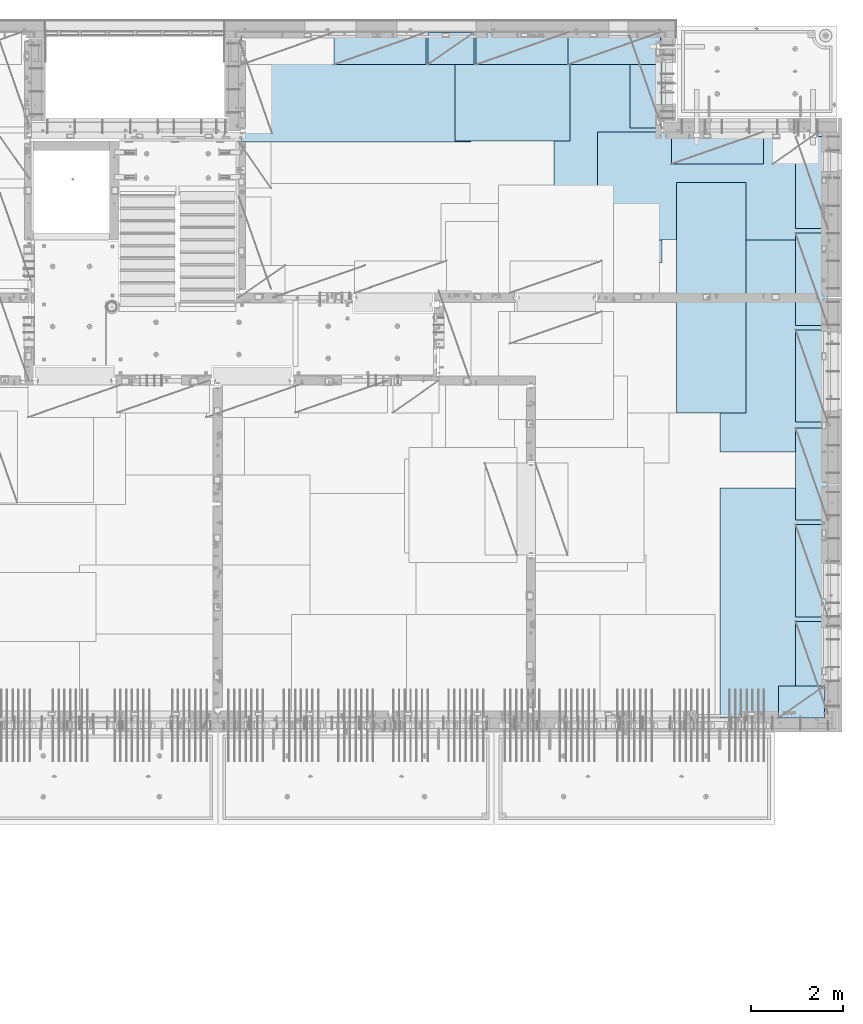
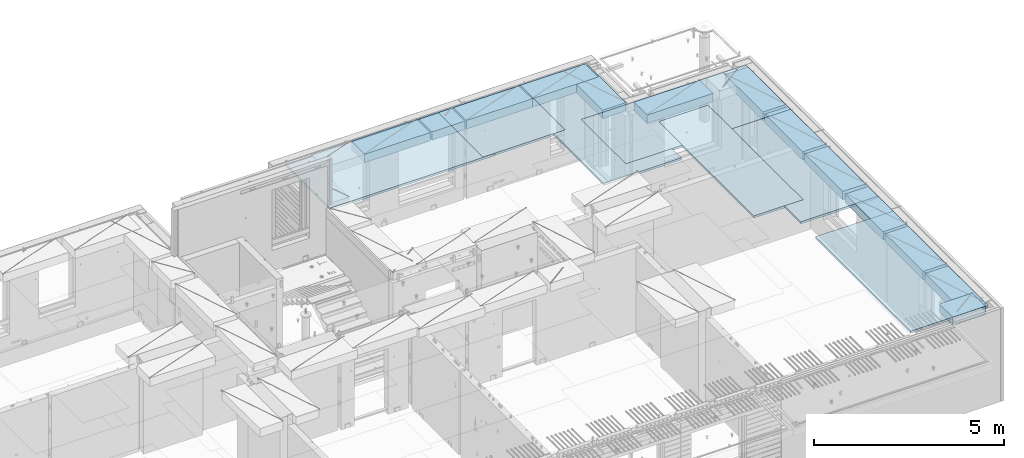
# One storey, part 211 of 350: 20 plates, 20 elements without a shape of their own.
"""IFC2X3 building model written with IfcOpenShell, lengths in millimetres."""

from ifc_helpers import new_model, si_unit, frame, origin_with_axes, place, context, subcontext, project, spatial, faceted_brep, material, type_object, element, aggregate, save


model = new_model("IFC2X3")

# Units and contexts
model_context = context("Model", 3, precision=1e-05, world=origin_with_axes())
body_context = subcontext(model_context, "Body", "Model", "MODEL_VIEW")
ifc_project = project(units=[si_unit("LENGTHUNIT", "METRE", prefix="MILLI"), si_unit("AREAUNIT", "SQUARE_METRE"), si_unit("VOLUMEUNIT", "CUBIC_METRE"), si_unit("MASSUNIT", "GRAM", prefix="KILO"), si_unit("TIMEUNIT", "SECOND"), si_unit("PLANEANGLEUNIT", "RADIAN"), si_unit("SOLIDANGLEUNIT", "STERADIAN"), si_unit("THERMODYNAMICTEMPERATUREUNIT", "DEGREE_CELSIUS"), si_unit("LUMINOUSINTENSITYUNIT", "LUMEN")], contexts=[model_context])

# Site, building, storey
site_placement = place(None, origin_with_axes())
site = spatial("IfcSite", under=ifc_project, at=site_placement, CompositionType="ELEMENT")
building_placement = place(site_placement, origin_with_axes())
building = spatial("IfcBuilding", under=site, at=building_placement, CompositionType="ELEMENT")
storey_placement = place(building_placement, origin_with_axes())
storey = spatial("IfcBuildingStorey", under=building, at=storey_placement, Name="2", CompositionType="ELEMENT", Elevation=0.0)

# Assembly, plate
assembly_1_placement = place(storey_placement, origin_with_axes())
assembly_1 = element("IfcElementAssembly", 1, at=assembly_1_placement, inside=storey, Name="Steel Assembly", AssemblyPlace="NOTDEFINED", PredefinedType="NOTDEFINED")
ifc_material = material()
plate_type_1 = type_object("IfcPlateType", PredefinedType="NOTDEFINED")
plate_1_placement = place(assembly_1_placement, frame((26960.07, 22728.45, 87695.1), z_axis=(1.0, 0.0, 0.0), x_axis=(0.0, -1.0, 0.0)))
plate_1 = element("IfcPlate", 2, at=plate_1_placement, type_object=plate_type_1, material=ifc_material, Name="1/2", context=body_context, shape_type="Brep", body=[
    faceted_brep([(0.0, -35.0, 0.0), (0.0, -35.0, 2500.0), (0.0, 35.0, 2500.0), (0.0, 35.0, 0.0), (2349.99951171875, -35.0, 2500.0), (2349.99951171875, 35.0, 2500.0), (2350.0, -35.0, 0.0), (2350.0, 35.0, 0.0)], [[[0, 1, 2, 3]], [[1, 4, 5, 2]], [[4, 6, 7, 5]], [[6, 0, 3, 7]], [[5, 7, 3, 2]], [[6, 4, 1, 0]]]),
])
aggregate(assembly_1, [plate_1])

assembly_2_placement = place(storey_placement, origin_with_axes())
assembly_2 = element("IfcElementAssembly", 3, at=assembly_2_placement, inside=storey, Name="Steel Assembly", AssemblyPlace="NOTDEFINED", PredefinedType="NOTDEFINED")
plate_2_placement = place(assembly_2_placement, frame((22309.9998779297, 22710.0009765625, 87695.1), z_axis=(1.0, 0.0, 0.0), x_axis=(0.0, -1.0, 0.0)))
plate_2 = element("IfcPlate", 4, at=plate_2_placement, type_object=plate_type_1, material=ifc_material, context=body_context, shape_type="Brep", body=[
    faceted_brep([(0.0, -35.0, 0.0), (0.0, -35.0, 5000.0), (0.0, 35.0, 5000.0), (0.0, 35.0, 0.0), (2349.99951171875, -35.0, 5000.0), (2349.99951171875, 35.0, 5000.0), (2350.0, -35.0, 0.0), (2350.0, 35.0, 0.0)], [[[0, 1, 2, 3]], [[1, 4, 5, 2]], [[4, 6, 7, 5]], [[6, 0, 3, 7]], [[5, 7, 3, 2]], [[6, 4, 1, 0]]]),
])
aggregate(assembly_2, [plate_2])

assembly_3_placement = place(storey_placement, origin_with_axes())
assembly_3 = element("IfcElementAssembly", 5, at=assembly_3_placement, inside=storey, Name="Steel Assembly", AssemblyPlace="NOTDEFINED", PredefinedType="NOTDEFINED")
plate_3_placement = place(assembly_3_placement, frame((31460.0, 22740.0, 87695.1), z_axis=(0.0, -1.0, 0.0), x_axis=(-1.0, 3.00000001838171e-08, 0.0)))
plate_3 = element("IfcPlate", 6, at=plate_3_placement, type_object=plate_type_1, material=ifc_material, context=body_context, shape_type="Brep", body=[
    faceted_brep([(0.0, -35.0, 0.0), (0.0, -35.0, 5000.0), (0.0, 35.0, 5000.0), (0.0, 35.0, 0.0), (2349.99951171875, -35.0, 5000.0), (2349.99951171875, 35.0, 5000.0), (2350.0, -35.0, 0.0), (2350.0, 35.0, 0.0)], [[[0, 1, 2, 3]], [[1, 4, 5, 2]], [[4, 6, 7, 5]], [[6, 0, 3, 7]], [[5, 7, 3, 2]], [[6, 4, 1, 0]]]),
])
aggregate(assembly_3, [plate_3])

assembly_4_placement = place(storey_placement, origin_with_axes())
assembly_4 = element("IfcElementAssembly", 7, at=assembly_4_placement, inside=storey, Name="Steel Assembly", AssemblyPlace="NOTDEFINED", PredefinedType="NOTDEFINED")
plate_4_placement = place(assembly_4_placement, frame((35060.0, 12850.0, 87695.1), z_axis=(0.0, -1.0, 0.0), x_axis=(-1.0, 3.00000001838171e-08, 0.0)))
plate_4 = element("IfcPlate", 8, at=plate_4_placement, type_object=plate_type_1, material=ifc_material, context=body_context, shape_type="Brep", body=[
    faceted_brep([(0.0, -35.0, 0.0), (0.0, -35.0, 5000.0), (0.0, 35.0, 5000.0), (0.0, 35.0, 0.0), (2349.99951171875, -35.0, 5000.0), (2349.99951171875, 35.0, 5000.0), (2350.0, -35.0, 0.0), (2350.0, 35.0, 0.0)], [[[0, 1, 2, 3]], [[1, 4, 5, 2]], [[4, 6, 7, 5]], [[6, 0, 3, 7]], [[5, 7, 3, 2]], [[6, 4, 1, 0]]]),
])
aggregate(assembly_4, [plate_4])

assembly_5_placement = place(storey_placement, origin_with_axes())
assembly_5 = element("IfcElementAssembly", 9, at=assembly_5_placement, inside=storey, Name="Steel Assembly", AssemblyPlace="NOTDEFINED", PredefinedType="NOTDEFINED")
plate_5_placement = place(assembly_5_placement, frame((35060.0, 18630.0, 87695.1), z_axis=(0.0, -1.0, 0.0), x_axis=(-1.0, 3.00000001838171e-08, 0.0)))
plate_5 = element("IfcPlate", 10, at=plate_5_placement, type_object=plate_type_1, material=ifc_material, context=body_context, shape_type="Brep", body=[
    faceted_brep([(0.0, -35.0, 0.0), (0.0, -35.0, 5000.0), (0.0, 35.0, 5000.0), (0.0, 35.0, 0.0), (2349.99951171875, -35.0, 5000.0), (2349.99951171875, 35.0, 5000.0), (2350.0, -35.0, 0.0), (2350.0, 35.0, 0.0)], [[[0, 1, 2, 3]], [[1, 4, 5, 2]], [[4, 6, 7, 5]], [[6, 0, 3, 7]], [[5, 7, 3, 2]], [[6, 4, 1, 0]]]),
])
aggregate(assembly_5, [plate_5])

assembly_6_placement = place(storey_placement, origin_with_axes())
assembly_6 = element("IfcElementAssembly", 11, at=assembly_6_placement, inside=storey, Name="Steel Assembly", AssemblyPlace="NOTDEFINED", PredefinedType="NOTDEFINED")
plate_6_placement = place(assembly_6_placement, frame((30060.0, 20580.0, 87695.1), z_axis=(1.0, 0.0, 0.0), x_axis=(0.0, -1.0, 0.0)))
plate_6 = element("IfcPlate", 12, at=plate_6_placement, type_object=plate_type_1, material=ifc_material, context=body_context, shape_type="Brep", body=[
    faceted_brep([(0.0, -35.0, 0.0), (0.0, -35.0, 5000.0), (0.0, 35.0, 5000.0), (0.0, 35.0, 0.0), (2349.99951171875, -35.0, 5000.0), (2349.99951171875, 35.0, 5000.0), (2350.0, -35.0, 0.0), (2350.0, 35.0, 0.0)], [[[0, 1, 2, 3]], [[1, 4, 5, 2]], [[4, 6, 7, 5]], [[6, 0, 3, 7]], [[5, 7, 3, 2]], [[6, 4, 1, 0]]]),
])
aggregate(assembly_6, [plate_6])

assembly_7_placement = place(storey_placement, origin_with_axes())
assembly_7 = element("IfcElementAssembly", 13, at=assembly_7_placement, inside=storey, Name="Steel Assembly", AssemblyPlace="NOTDEFINED", PredefinedType="NOTDEFINED")
plate_type_2 = type_object("IfcPlateType", PredefinedType="NOTDEFINED")
plate_7_placement = place(assembly_7_placement, frame((33275.0000122641, 19480.0, 87695.1000003815), z_axis=(0.0, -1.0, 0.0), x_axis=(-1.0, 3.00000001838171e-08, 0.0)))
plate_7 = element("IfcPlate", 14, at=plate_7_placement, type_object=plate_type_2, material=ifc_material, context=body_context, shape_type="Brep", body=[
    faceted_brep([(0.0, -35.0, 0.0), (0.0, -35.0, 5000.0), (0.0, 35.0, 5000.0), (0.0, 35.0, 0.0), (1499.99951171875, -35.0, 5000.0), (1499.99951171875, 35.0, 5000.0), (1500.0, -35.0, 0.0), (1500.0, 35.0, 0.0)], [[[0, 1, 2, 3]], [[1, 4, 5, 2]], [[4, 6, 7, 5]], [[6, 0, 3, 7]], [[5, 7, 3, 2]], [[6, 4, 1, 0]]]),
])
aggregate(assembly_7, [plate_7])

assembly_8_placement = place(storey_placement, origin_with_axes())
assembly_8 = element("IfcElementAssembly", 15, at=assembly_8_placement, inside=storey, Name="Steel Assembly", AssemblyPlace="NOTDEFINED", PredefinedType="NOTDEFINED")
plate_type_3 = type_object("IfcPlateType", PredefinedType="NOTDEFINED")
plate_8_placement = place(assembly_8_placement, frame((31420.0, 22740.0001220703, 87595.3), z_axis=(0.0, -1.0, 0.0), x_axis=(-1.0, 3.00000001838171e-08, 0.0)))
plate_8 = element("IfcPlate", 16, at=plate_8_placement, type_object=plate_type_3, material=ifc_material, Name="RE1", context=body_context, shape_type="Brep", body=[
    faceted_brep([(1.81898940354586e-12, -135.0, 1.81898940354586e-12), (0.0, -135.0, 699.999999999996), (0.0, 135.0, 699.999999999996), (1.81898940354586e-12, 135.0, 1.81898940354586e-12), (1999.99951171875, -135.0, 699.999999999993), (1999.99951171875, 135.0, 699.999999999993), (2000.0, -135.0, -3.63797880709171e-12), (2000.0, 135.0, -3.63797880709171e-12)], [[[0, 1, 2, 3]], [[1, 4, 5, 2]], [[4, 6, 7, 5]], [[6, 0, 3, 7]], [[5, 7, 3, 2]], [[6, 4, 1, 0]]]),
])
aggregate(assembly_8, [plate_8])

assembly_9_placement = place(storey_placement, origin_with_axes())
assembly_9 = element("IfcElementAssembly", 17, at=assembly_9_placement, inside=storey, Name="Steel Assembly", AssemblyPlace="NOTDEFINED", PredefinedType="NOTDEFINED")
plate_9_placement = place(assembly_9_placement, frame((33985.0, 7849.99999992931, 87595.3), z_axis=(0.0, 1.0, 0.0), x_axis=(1.0, 0.0, 0.0)))
plate_9 = element("IfcPlate", 18, at=plate_9_placement, type_object=plate_type_3, material=ifc_material, Name="RE1_1/2", context=body_context, shape_type="Brep", body=[
    faceted_brep([(1.81898940354586e-12, -135.0, 1.81898940354586e-12), (0.0, -135.0, 699.999999999996), (0.0, 135.0, 699.999999999996), (1.81898940354586e-12, 135.0, 1.81898940354586e-12), (999.99951171875, -135.0, 700.0), (999.99951171875, 135.0, 700.0), (1000.0, -135.0, 0.0), (1000.0, 135.0, 0.0)], [[[0, 1, 2, 3]], [[1, 4, 5, 2]], [[4, 6, 7, 5]], [[6, 0, 3, 7]], [[5, 7, 3, 2]], [[6, 4, 1, 0]]]),
])
aggregate(assembly_9, [plate_9])

assembly_10_placement = place(storey_placement, origin_with_axes())
assembly_10 = element("IfcElementAssembly", 19, at=assembly_10_placement, inside=storey, Name="Steel Assembly", AssemblyPlace="NOTDEFINED", PredefinedType="NOTDEFINED")
plate_10_placement = place(assembly_10_placement, frame((35060.0001220703, 14280.0, 87595.3), z_axis=(-1.0, 3.00000001838171e-08, 0.0), x_axis=(0.0, 1.0, 0.0)))
plate_10 = element("IfcPlate", 20, at=plate_10_placement, type_object=plate_type_3, material=ifc_material, Name="RE1", context=body_context, shape_type="Brep", body=[
    faceted_brep([(1.81898940354586e-12, -135.0, 1.81898940354586e-12), (0.0, -135.0, 699.999999999996), (0.0, 135.0, 699.999999999996), (1.81898940354586e-12, 135.0, 1.81898940354586e-12), (1999.99951171875, -135.0, 699.999999999993), (1999.99951171875, 135.0, 699.999999999993), (2000.0, -135.0, -3.63797880709171e-12), (2000.0, 135.0, -3.63797880709171e-12)], [[[0, 1, 2, 3]], [[1, 4, 5, 2]], [[4, 6, 7, 5]], [[6, 0, 3, 7]], [[5, 7, 3, 2]], [[6, 4, 1, 0]]]),
])
aggregate(assembly_10, [plate_10])

assembly_11_placement = place(storey_placement, origin_with_axes())
assembly_11 = element("IfcElementAssembly", 21, at=assembly_11_placement, inside=storey, Name="Steel Assembly", AssemblyPlace="NOTDEFINED", PredefinedType="NOTDEFINED")
plate_11_placement = place(assembly_11_placement, frame((35060.0001220703, 16380.0, 87595.3), z_axis=(-1.0, 3.00000001838171e-08, 0.0), x_axis=(0.0, 1.0, 0.0)))
plate_11 = element("IfcPlate", 22, at=plate_11_placement, type_object=plate_type_3, material=ifc_material, Name="RE1", context=body_context, shape_type="Brep", body=[
    faceted_brep([(1.81898940354586e-12, -135.0, 1.81898940354586e-12), (0.0, -135.0, 699.999999999996), (0.0, 135.0, 699.999999999996), (1.81898940354586e-12, 135.0, 1.81898940354586e-12), (1999.99951171875, -135.0, 699.999999999993), (1999.99951171875, 135.0, 699.999999999993), (2000.0, -135.0, -3.63797880709171e-12), (2000.0, 135.0, -3.63797880709171e-12)], [[[0, 1, 2, 3]], [[1, 4, 5, 2]], [[4, 6, 7, 5]], [[6, 0, 3, 7]], [[5, 7, 3, 2]], [[6, 4, 1, 0]]]),
])
aggregate(assembly_11, [plate_11])

assembly_12_placement = place(storey_placement, origin_with_axes())
assembly_12 = element("IfcElementAssembly", 23, at=assembly_12_placement, inside=storey, Name="Steel Assembly", AssemblyPlace="NOTDEFINED", PredefinedType="NOTDEFINED")
plate_12_placement = place(assembly_12_placement, frame((35060.0001220703, 18480.0, 87595.3), z_axis=(-1.0, 3.00000001838171e-08, 0.0), x_axis=(0.0, 1.0, 0.0)))
plate_12 = element("IfcPlate", 24, at=plate_12_placement, type_object=plate_type_3, material=ifc_material, Name="RE1", context=body_context, shape_type="Brep", body=[
    faceted_brep([(1.81898940354586e-12, -135.0, 1.81898940354586e-12), (0.0, -135.0, 699.999999999996), (0.0, 135.0, 699.999999999996), (1.81898940354586e-12, 135.0, 1.81898940354586e-12), (1999.99951171875, -135.0, 699.999999999993), (1999.99951171875, 135.0, 699.999999999993), (2000.0, -135.0, -3.63797880709171e-12), (2000.0, 135.0, -3.63797880709171e-12)], [[[0, 1, 2, 3]], [[1, 4, 5, 2]], [[4, 6, 7, 5]], [[6, 0, 3, 7]], [[5, 7, 3, 2]], [[6, 4, 1, 0]]]),
])
aggregate(assembly_12, [plate_12])

assembly_13_placement = place(storey_placement, origin_with_axes())
assembly_13 = element("IfcElementAssembly", 25, at=assembly_13_placement, inside=storey, Name="Steel Assembly", AssemblyPlace="NOTDEFINED", PredefinedType="NOTDEFINED")
plate_13_placement = place(assembly_13_placement, frame((35060.0001220703, 12150.0, 87595.3), z_axis=(-1.0, 3.00000001838171e-08, 0.0), x_axis=(0.0, 1.0, 0.0)))
plate_13 = element("IfcPlate", 26, at=plate_13_placement, type_object=plate_type_3, material=ifc_material, Name="RE1", context=body_context, shape_type="Brep", body=[
    faceted_brep([(1.81898940354586e-12, -135.0, 1.81898940354586e-12), (0.0, -135.0, 699.999999999996), (0.0, 135.0, 699.999999999996), (1.81898940354586e-12, 135.0, 1.81898940354586e-12), (1999.99951171875, -135.0, 699.999999999993), (1999.99951171875, 135.0, 699.999999999993), (2000.0, -135.0, -3.63797880709171e-12), (2000.0, 135.0, -3.63797880709171e-12)], [[[0, 1, 2, 3]], [[1, 4, 5, 2]], [[4, 6, 7, 5]], [[6, 0, 3, 7]], [[5, 7, 3, 2]], [[6, 4, 1, 0]]]),
])
aggregate(assembly_13, [plate_13])

assembly_14_placement = place(storey_placement, origin_with_axes())
assembly_14 = element("IfcElementAssembly", 27, at=assembly_14_placement, inside=storey, Name="Steel Assembly", AssemblyPlace="NOTDEFINED", PredefinedType="NOTDEFINED")
plate_14_placement = place(assembly_14_placement, frame((35060.0001220703, 10050.0, 87595.3), z_axis=(-1.0, 3.00000001838171e-08, 0.0), x_axis=(0.0, 1.0, 0.0)))
plate_14 = element("IfcPlate", 28, at=plate_14_placement, type_object=plate_type_3, material=ifc_material, Name="RE1", context=body_context, shape_type="Brep", body=[
    faceted_brep([(1.81898940354586e-12, -135.0, 1.81898940354586e-12), (0.0, -135.0, 699.999999999996), (0.0, 135.0, 699.999999999996), (1.81898940354586e-12, 135.0, 1.81898940354586e-12), (1999.99951171875, -135.0, 699.999999999993), (1999.99951171875, 135.0, 699.999999999993), (2000.0, -135.0, -3.63797880709171e-12), (2000.0, 135.0, -3.63797880709171e-12)], [[[0, 1, 2, 3]], [[1, 4, 5, 2]], [[4, 6, 7, 5]], [[6, 0, 3, 7]], [[5, 7, 3, 2]], [[6, 4, 1, 0]]]),
])
aggregate(assembly_14, [plate_14])

assembly_15_placement = place(storey_placement, origin_with_axes())
assembly_15 = element("IfcElementAssembly", 29, at=assembly_15_placement, inside=storey, Name="Steel Assembly", AssemblyPlace="NOTDEFINED", PredefinedType="NOTDEFINED")
plate_15_placement = place(assembly_15_placement, frame((35060.0001220703, 7950.0, 87595.3), z_axis=(-1.0, 3.00000001838171e-08, 0.0), x_axis=(0.0, 1.0, 0.0)))
plate_15 = element("IfcPlate", 30, at=plate_15_placement, type_object=plate_type_3, material=ifc_material, Name="RE1", context=body_context, shape_type="Brep", body=[
    faceted_brep([(1.81898940354586e-12, -135.0, 1.81898940354586e-12), (0.0, -135.0, 699.999999999996), (0.0, 135.0, 699.999999999996), (1.81898940354586e-12, 135.0, 1.81898940354586e-12), (1999.99951171875, -135.0, 699.999999999993), (1999.99951171875, 135.0, 699.999999999993), (2000.0, -135.0, -3.63797880709171e-12), (2000.0, 135.0, -3.63797880709171e-12)], [[[0, 1, 2, 3]], [[1, 4, 5, 2]], [[4, 6, 7, 5]], [[6, 0, 3, 7]], [[5, 7, 3, 2]], [[6, 4, 1, 0]]]),
])
aggregate(assembly_15, [plate_15])

assembly_16_placement = place(storey_placement, origin_with_axes())
assembly_16 = element("IfcElementAssembly", 31, at=assembly_16_placement, inside=storey, Name="Steel Assembly", AssemblyPlace="NOTDEFINED", PredefinedType="NOTDEFINED")
plate_16_placement = place(assembly_16_placement, frame((33660.0, 20580.0001220703, 87595.3), z_axis=(0.0, -1.0, 0.0), x_axis=(-1.0, 3.00000001838171e-08, 0.0)))
plate_16 = element("IfcPlate", 32, at=plate_16_placement, type_object=plate_type_3, material=ifc_material, Name="RE1", context=body_context, shape_type="Brep", body=[
    faceted_brep([(1.81898940354586e-12, -135.0, 1.81898940354586e-12), (0.0, -135.0, 699.999999999996), (0.0, 135.0, 699.999999999996), (1.81898940354586e-12, 135.0, 1.81898940354586e-12), (1999.99951171875, -135.0, 699.999999999993), (1999.99951171875, 135.0, 699.999999999993), (2000.0, -135.0, -3.63797880709171e-12), (2000.0, 135.0, -3.63797880709171e-12)], [[[0, 1, 2, 3]], [[1, 4, 5, 2]], [[4, 6, 7, 5]], [[6, 0, 3, 7]], [[5, 7, 3, 2]], [[6, 4, 1, 0]]]),
])
aggregate(assembly_16, [plate_16])

assembly_17_placement = place(storey_placement, origin_with_axes())
assembly_17 = element("IfcElementAssembly", 33, at=assembly_17_placement, inside=storey, Name="Steel Assembly", AssemblyPlace="NOTDEFINED", PredefinedType="NOTDEFINED")
plate_17_placement = place(assembly_17_placement, frame((31460.0001220703, 20660.0, 87595.3), z_axis=(-1.0, 3.00000001838171e-08, 0.0), x_axis=(0.0, 1.0, 0.0)))
plate_17 = element("IfcPlate", 34, at=plate_17_placement, type_object=plate_type_3, material=ifc_material, Name="RE1", context=body_context, shape_type="Brep", body=[
    faceted_brep([(1.81898940354586e-12, -135.0, 1.81898940354586e-12), (0.0, -135.0, 699.999999999996), (0.0, 135.0, 699.999999999996), (1.81898940354586e-12, 135.0, 1.81898940354586e-12), (1999.99951171875, -135.0, 699.999999999993), (1999.99951171875, 135.0, 699.999999999993), (2000.0, -135.0, -3.63797880709171e-12), (2000.0, 135.0, -3.63797880709171e-12)], [[[0, 1, 2, 3]], [[1, 4, 5, 2]], [[4, 6, 7, 5]], [[6, 0, 3, 7]], [[5, 7, 3, 2]], [[6, 4, 1, 0]]]),
])
aggregate(assembly_17, [plate_17])

assembly_18_placement = place(storey_placement, origin_with_axes())
assembly_18 = element("IfcElementAssembly", 35, at=assembly_18_placement, inside=storey, Name="Steel Assembly", AssemblyPlace="NOTDEFINED", PredefinedType="NOTDEFINED")
plate_18_placement = place(assembly_18_placement, frame((26330.0, 22740.0001220703, 87595.3), z_axis=(0.0, -1.0, 0.0), x_axis=(-1.0, 3.00000001838171e-08, 0.0)))
plate_18 = element("IfcPlate", 36, at=plate_18_placement, type_object=plate_type_3, material=ifc_material, Name="RE1", context=body_context, shape_type="Brep", body=[
    faceted_brep([(1.81898940354586e-12, -135.0, 1.81898940354586e-12), (0.0, -135.0, 699.999999999996), (0.0, 135.0, 699.999999999996), (1.81898940354586e-12, 135.0, 1.81898940354586e-12), (1999.99951171875, -135.0, 699.999999999993), (1999.99951171875, 135.0, 699.999999999993), (2000.0, -135.0, -3.63797880709171e-12), (2000.0, 135.0, -3.63797880709171e-12)], [[[0, 1, 2, 3]], [[1, 4, 5, 2]], [[4, 6, 7, 5]], [[6, 0, 3, 7]], [[5, 7, 3, 2]], [[6, 4, 1, 0]]]),
])
aggregate(assembly_18, [plate_18])

assembly_19_placement = place(storey_placement, origin_with_axes())
assembly_19 = element("IfcElementAssembly", 37, at=assembly_19_placement, inside=storey, Name="Steel Assembly", AssemblyPlace="NOTDEFINED", PredefinedType="NOTDEFINED")
plate_19_placement = place(assembly_19_placement, frame((29420.0, 22740.0001220703, 87595.3), z_axis=(0.0, -1.0, 0.0), x_axis=(-1.0, 3.00000001838171e-08, 0.0)))
plate_19 = element("IfcPlate", 38, at=plate_19_placement, type_object=plate_type_3, material=ifc_material, Name="RE1", context=body_context, shape_type="Brep", body=[
    faceted_brep([(1.81898940354586e-12, -135.0, 1.81898940354586e-12), (0.0, -135.0, 699.999999999996), (0.0, 135.0, 699.999999999996), (1.81898940354586e-12, 135.0, 1.81898940354586e-12), (1999.99951171875, -135.0, 699.999999999993), (1999.99951171875, 135.0, 699.999999999993), (2000.0, -135.0, -3.63797880709171e-12), (2000.0, 135.0, -3.63797880709171e-12)], [[[0, 1, 2, 3]], [[1, 4, 5, 2]], [[4, 6, 7, 5]], [[6, 0, 3, 7]], [[5, 7, 3, 2]], [[6, 4, 1, 0]]]),
])
aggregate(assembly_19, [plate_19])

assembly_20_placement = place(storey_placement, origin_with_axes())
assembly_20 = element("IfcElementAssembly", 39, at=assembly_20_placement, inside=storey, Name="Steel Assembly", AssemblyPlace="NOTDEFINED", PredefinedType="NOTDEFINED")
plate_20_placement = place(assembly_20_placement, frame((27375.0, 22740.0000000707, 87595.3), z_axis=(0.0, -1.0, 0.0), x_axis=(-1.0, 3.00000001838171e-08, 0.0)))
plate_20 = element("IfcPlate", 40, at=plate_20_placement, type_object=plate_type_3, material=ifc_material, Name="RE1_1/2", context=body_context, shape_type="Brep", body=[
    faceted_brep([(1.81898940354586e-12, -135.0, 1.81898940354586e-12), (0.0, -135.0, 699.999999999996), (0.0, 135.0, 699.999999999996), (1.81898940354586e-12, 135.0, 1.81898940354586e-12), (999.99951171875, -135.0, 700.0), (999.99951171875, 135.0, 700.0), (1000.0, -135.0, 0.0), (1000.0, 135.0, 0.0)], [[[0, 1, 2, 3]], [[1, 4, 5, 2]], [[4, 6, 7, 5]], [[6, 0, 3, 7]], [[5, 7, 3, 2]], [[6, 4, 1, 0]]]),
])
aggregate(assembly_20, [plate_20])

save(model, "model.ifc")
